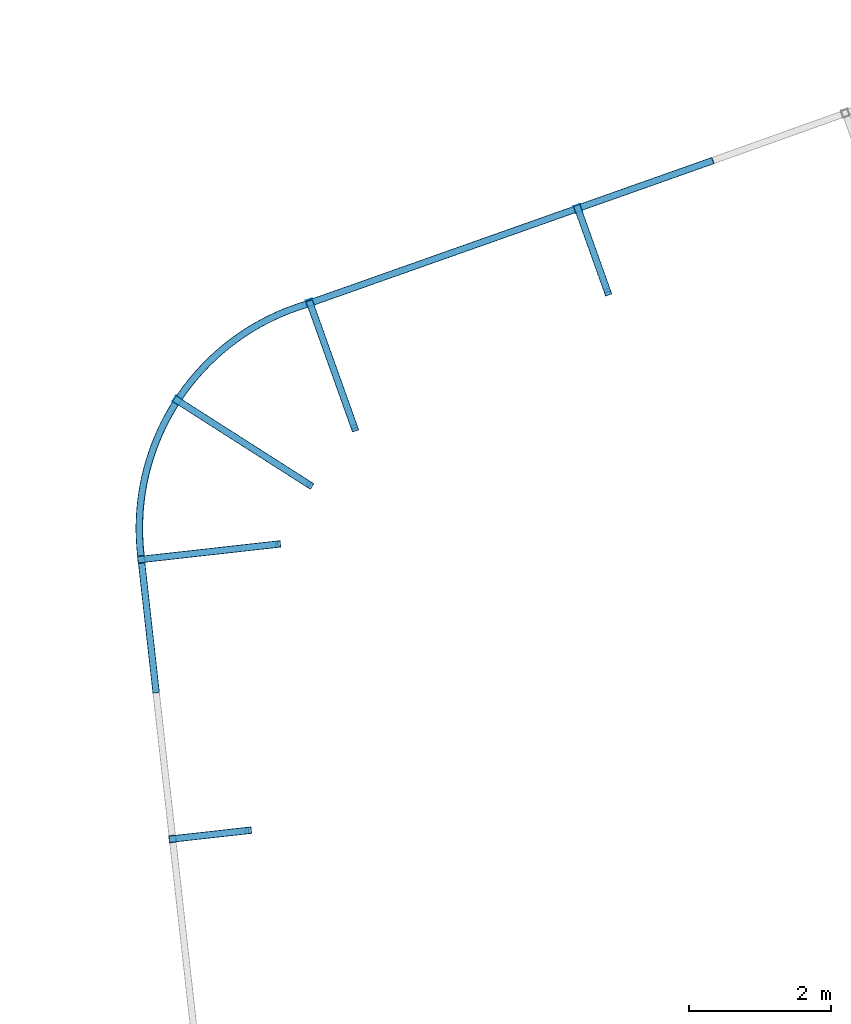
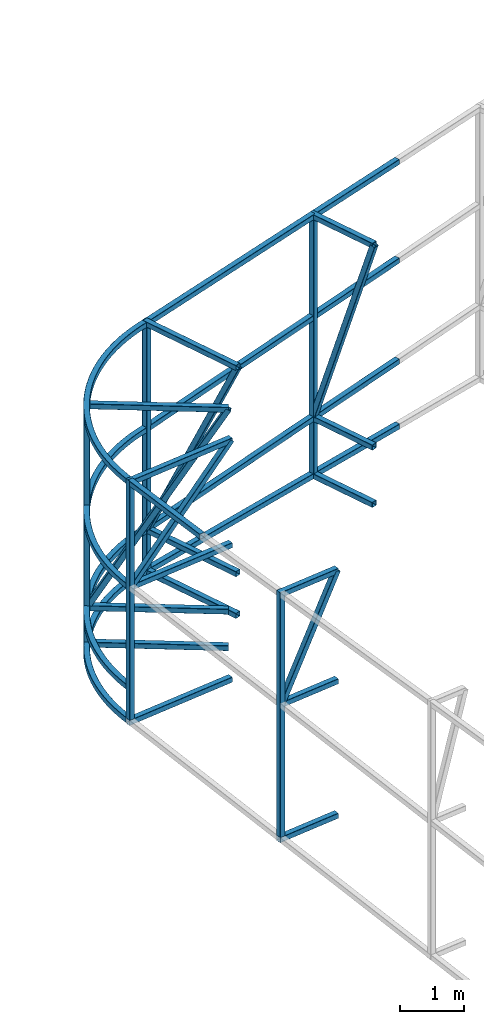
# One storey, part 126 of 215: 29 beams, 5 members, 34 elements without a shape of their own.
"""IFC2X3 building model written with IfcOpenShell, lengths in millimetres."""

from ifc_helpers import new_model, entity, si_unit, frame, origin_with_axes, origin_2d_with_axis, place, context, subcontext, project, spatial, hollow_rectangle, extrude, material, type_object, element, aggregate, save


model = new_model("IFC2X3")

# Units and contexts
model_context = context("Model", 3, precision=1e-05, world=origin_with_axes())
body_context = subcontext(model_context, "Body", "Model", "MODEL_VIEW")
ifc_project = project(units=[si_unit("LENGTHUNIT", "METRE", prefix="MILLI"), si_unit("AREAUNIT", "SQUARE_METRE"), si_unit("VOLUMEUNIT", "CUBIC_METRE"), si_unit("MASSUNIT", "GRAM", prefix="KILO"), si_unit("TIMEUNIT", "SECOND"), si_unit("PLANEANGLEUNIT", "RADIAN"), si_unit("SOLIDANGLEUNIT", "STERADIAN"), si_unit("THERMODYNAMICTEMPERATUREUNIT", "DEGREE_CELSIUS"), si_unit("LUMINOUSINTENSITYUNIT", "LUMEN")], contexts=[model_context])

# Site, building, storey
site_placement = place(None, origin_with_axes())
site = spatial("IfcSite", under=ifc_project, at=site_placement, CompositionType="ELEMENT")
building_placement = place(site_placement, origin_with_axes())
building = spatial("IfcBuilding", under=site, at=building_placement, Name="Undefined", CompositionType="ELEMENT")
storey_placement = place(building_placement, origin_with_axes())
storey = spatial("IfcBuildingStorey", under=building, at=storey_placement, Name="Undefined", CompositionType="ELEMENT", Elevation=0.0)

# Assembly, beam
assembly_1_placement = place(storey_placement, origin_with_axes())
assembly_1 = element("IfcElementAssembly", 1, at=assembly_1_placement, inside=storey, Name="Steel Assembly", AssemblyPlace="NOTDEFINED", PredefinedType="RIGID_FRAME")
ifc_material = material(Name="STEEL/S275JR")
beam_type = type_object("IfcBeamType", PredefinedType="NOTDEFINED")
beam_1_placement = place(assembly_1_placement, frame((91607.248032697, 68580.9446673128, 2617.76875948124), z_axis=(0.834469392374245, -0.550396256246836, -0.0269220040120741), x_axis=(0.549440398154308, 0.834768266234439, -0.0357378030100368)))
beam_1 = element("IfcBeam", 2, at=beam_1_placement, type_object=beam_type, material=ifc_material, Name="LISSE", context=body_context, shape_type="SweptSolid", body=[
    entity("IfcRevolvedAreaSolid", entity("IfcRectangleHollowProfileDef", "AREA", None, entity("IfcAxis2Placement2D", entity("IfcCartesianPoint", [0.0, 0.0]), entity("IfcDirection", [1.0, 0.0])), 100.0, 100.0, 4.0, 4.0, 8.0), entity("IfcAxis2Placement3D", entity("IfcCartesianPoint", [4253.07055519195, -2.95116053483087e-14, -7.49913912963001e-12]), entity("IfcDirection", [-0.764684688863916, 7.54179360387119e-18, -0.644404629574537]), entity("IfcDirection", [-6.93889390390723e-18, -1.0, -3.46944695195361e-18])), entity("IfcAxis1Placement", entity("IfcCartesianPoint", [0.0, 3300.0, 0.0]), entity("IfcDirection", [-1.0, 0.0, 0.0])), 1.40048888931298),
])
aggregate(assembly_1, [beam_1])

assembly_2_placement = place(storey_placement, origin_with_axes())
assembly_2 = element("IfcElementAssembly", 3, at=assembly_2_placement, inside=storey, Name="Steel Assembly", AssemblyPlace="NOTDEFINED", PredefinedType="RIGID_FRAME")
beam_2_placement = place(assembly_2_placement, frame((93991.6038532737, 72148.0113620738, 2462.13444631614), z_axis=(-0.0695733440169439, -0.0246100800059907, -0.997273229242818), x_axis=(0.940198367836506, 0.332537099942175, -0.0737977389871672)))
beam_2 = element("IfcBeam", 4, at=beam_2_placement, type_object=beam_type, material=ifc_material, Name="LISSE", context=body_context, shape_type="SweptSolid", body=[
    extrude(hollow_rectangle(XDim=100.0, YDim=100.0, WallThickness=4.0, InnerFilletRadius=4.0, OuterFilletRadius=8.0, at=origin_2d_with_axis()), frame((6049.10274749353, -7.56716882113975e-12, 8.39481643573826e-14), z_axis=(-1.0, 0.0, 0.0), x_axis=(-6.93889390390723e-18, -1.0, -3.46944695195361e-18)), (0.0, 0.0, 1.0), 6049.1),
])
aggregate(assembly_2, [beam_2])

assembly_3_placement = place(storey_placement, origin_with_axes())
assembly_3 = element("IfcElementAssembly", 5, at=assembly_3_placement, inside=storey, Name="Steel Assembly", AssemblyPlace="NOTDEFINED", PredefinedType="RIGID_FRAME")
beam_3_placement = place(assembly_3_placement, frame((91605.3363023384, 68580.2609110782, 7185.12016069465), z_axis=(0.835271355040967, -0.549834651026962, 0.00190262400009359), x_axis=(0.549829823840989, 0.835272824758436, 0.00254421599926422)))
beam_3 = element("IfcBeam", 6, at=beam_3_placement, type_object=beam_type, material=ifc_material, Name="LISSE", context=body_context, shape_type="SweptSolid", body=[
    entity("IfcRevolvedAreaSolid", entity("IfcRectangleHollowProfileDef", "AREA", None, entity("IfcAxis2Placement2D", entity("IfcCartesianPoint", [0.0, 0.0]), entity("IfcDirection", [1.0, 0.0])), 100.0, 100.0, 4.0, 4.0, 8.0), entity("IfcAxis2Placement3D", entity("IfcCartesianPoint", [4250.63753103631, 9.07651281594689e-13, 1.46771453858659e-11]), entity("IfcDirection", [-0.764995192248369, 3.31763779750659e-19, -0.644035989550958]), entity("IfcDirection", [-6.93889390390723e-18, -1.0, -3.46944695195361e-18])), entity("IfcAxis1Placement", entity("IfcCartesianPoint", [0.0, 3300.0, 0.0]), entity("IfcDirection", [-1.0, 0.0, 0.0])), 1.39952492287531),
])
aggregate(assembly_3, [beam_3])

assembly_4_placement = place(storey_placement, origin_with_axes())
assembly_4 = element("IfcElementAssembly", 7, at=assembly_4_placement, inside=storey, Name="Steel Assembly", AssemblyPlace="NOTDEFINED", PredefinedType="RIGID_FRAME")
beam_4_placement = place(assembly_4_placement, frame((93992.0527159489, 72148.1696476827, 7194.91794063586), z_axis=(-0.0194644239945866, -0.00689095799808525, -0.999786802721674), x_axis=(0.942568087150264, 0.333375242053147, -0.0206482220032917)))
beam_4 = element("IfcBeam", 8, at=beam_4_placement, type_object=beam_type, material=ifc_material, Name="LISSE", context=body_context, shape_type="SweptSolid", body=[
    extrude(hollow_rectangle(XDim=100.0, YDim=100.0, WallThickness=4.0, InnerFilletRadius=4.0, OuterFilletRadius=8.0, at=origin_2d_with_axis()), frame((6028.69527728381, -7.7446509143902e-14, 1.79807316509183e-12), z_axis=(-1.0, 0.0, 0.0), x_axis=(-6.93889390390723e-18, -1.0, -3.46944695195361e-18)), (0.0, 0.0, 1.0), 6028.7),
])
aggregate(assembly_4, [beam_4])

assembly_5_placement = place(storey_placement, origin_with_axes())
assembly_5 = element("IfcElementAssembly", 9, at=assembly_5_placement, inside=storey, Name="Steel Assembly", AssemblyPlace="NOTDEFINED", PredefinedType="RIGID_FRAME")
beam_5_placement = place(assembly_5_placement, frame((93124.0754360827, 64705.462066783, 2619.99965660268), z_axis=(-0.111241487973639, 0.993793404764497, 0.0), x_axis=(-0.993793404764496, -0.111241487973643, 0.0)))
beam_5 = element("IfcBeam", 10, at=beam_5_placement, type_object=beam_type, material=ifc_material, Name="LISSE", context=body_context, shape_type="SweptSolid", body=[
    extrude(hollow_rectangle(XDim=100.0, YDim=100.0, WallThickness=4.0, InnerFilletRadius=4.0, OuterFilletRadius=8.0, at=origin_2d_with_axis()), frame((1128.31775918118, 0.0, 0.0), z_axis=(-1.0, 0.0, 0.0), x_axis=(-6.93889390390723e-18, -1.0, -3.46944695195361e-18)), (0.0, 0.0, 1.0), 1128.3),
])
aggregate(assembly_5, [beam_5])

assembly_6_placement = place(storey_placement, origin_with_axes())
assembly_6 = element("IfcElementAssembly", 11, at=assembly_6_placement, inside=storey, Name="Steel Assembly", AssemblyPlace="NOTDEFINED", PredefinedType="RIGID_FRAME")
beam_6_placement = place(assembly_6_placement, frame((93124.0754354593, 64705.4620598467, 5185.9679099935), z_axis=(-0.111241487973639, 0.993793404764497, 0.0), x_axis=(-0.993793404764496, -0.111241487973643, 0.0)))
beam_6 = element("IfcBeam", 12, at=beam_6_placement, type_object=beam_type, material=ifc_material, Name="LISSE", context=body_context, shape_type="SweptSolid", body=[
    extrude(hollow_rectangle(XDim=100.0, YDim=100.0, WallThickness=4.0, InnerFilletRadius=4.0, OuterFilletRadius=8.0, at=origin_2d_with_axis()), frame((1128.31775918118, 0.0, 0.0), z_axis=(-1.0, 0.0, 0.0), x_axis=(-6.93889390390723e-18, -1.0, -3.46944695195361e-18)), (0.0, 0.0, 1.0), 1128.3),
])
aggregate(assembly_6, [beam_6])

assembly_7_placement = place(storey_placement, origin_with_axes())
assembly_7 = element("IfcElementAssembly", 13, at=assembly_7_placement, inside=storey, Name="Steel Assembly", AssemblyPlace="NOTDEFINED", PredefinedType="RIGID_FRAME")
beam_7_placement = place(assembly_7_placement, frame((93124.0754363296, 64705.4620685317, 7292.68372931973), z_axis=(-0.111241487973639, 0.993793404764497, 0.0), x_axis=(-0.993793404764496, -0.111241487973643, 0.0)))
beam_7 = element("IfcBeam", 14, at=beam_7_placement, type_object=beam_type, material=ifc_material, Name="LISSE", context=body_context, shape_type="SweptSolid", body=[
    extrude(hollow_rectangle(XDim=100.0, YDim=100.0, WallThickness=4.0, InnerFilletRadius=4.0, OuterFilletRadius=8.0, at=origin_2d_with_axis()), frame((1128.31775918118, 0.0, 0.0), z_axis=(-1.0, 0.0, 0.0), x_axis=(-6.93889390390723e-18, -1.0, -3.46944695195361e-18)), (0.0, 0.0, 1.0), 1128.3),
])
aggregate(assembly_7, [beam_7])

assembly_8_placement = place(storey_placement, origin_with_axes())
assembly_8 = element("IfcElementAssembly", 15, at=assembly_8_placement, inside=storey, Name="Steel Assembly", AssemblyPlace="NOTDEFINED", PredefinedType="RIGID_FRAME")
beam_8_placement = place(assembly_8_placement, frame((92052.3278067538, 64585.4969557288, 7341.91481389549), z_axis=(-0.111238280970791, 0.993793763739068, 0.0), x_axis=(0.0, 0.0, -1.0)))
beam_8 = element("IfcBeam", 16, at=beam_8_placement, type_object=beam_type, material=ifc_material, Name="LISSE", context=body_context, shape_type="SweptSolid", body=[
    extrude(hollow_rectangle(XDim=100.0, YDim=100.0, WallThickness=4.0, InnerFilletRadius=4.0, OuterFilletRadius=8.0, at=origin_2d_with_axis()), frame((4671.91515736343, 0.0, 0.0), z_axis=(-1.0, 0.0, 0.0), x_axis=(-6.93889390390723e-18, -1.0, -3.46944695195361e-18)), (0.0, 0.0, 1.0), 4671.9),
])
aggregate(assembly_8, [beam_8])

assembly_9_placement = place(storey_placement, origin_with_axes())
assembly_9 = element("IfcElementAssembly", 17, at=assembly_9_placement, inside=storey, Name="Steel Assembly", AssemblyPlace="NOTDEFINED", PredefinedType="RIGID_FRAME")
beam_9_placement = place(assembly_9_placement, frame((91605.1866103333, 68580.2059175499, 3259.91320502484), z_axis=(0.835301858925206, -0.549791600950776, 2.8100000006119e-07), x_axis=(0.54979160084285, 0.83530185876124, 1.98159999943166e-05)))
beam_9 = element("IfcBeam", 18, at=beam_9_placement, type_object=beam_type, material=ifc_material, Name="LISSE", context=body_context, shape_type="SweptSolid", body=[
    entity("IfcRevolvedAreaSolid", entity("IfcRectangleHollowProfileDef", "AREA", None, entity("IfcAxis2Placement2D", entity("IfcCartesianPoint", [0.0, 0.0]), entity("IfcDirection", [1.0, 0.0])), 100.0, 100.0, 4.0, 4.0, 8.0), entity("IfcAxis2Placement3D", entity("IfcCartesianPoint", [4250.35466927494, -4.54747350886464e-13, -1.17235734839679e-13]), entity("IfcDirection", [-0.765031271460523, 6.81854250453037e-23, -0.643993131708325]), entity("IfcDirection", [-6.93889390390723e-18, -1.0, -3.46944695195361e-18])), entity("IfcAxis1Placement", entity("IfcCartesianPoint", [0.0, 3300.0, 0.0]), entity("IfcDirection", [-1.0, 0.0, 0.0])), 1.39941287816592),
])
aggregate(assembly_9, [beam_9])

assembly_10_placement = place(storey_placement, origin_with_axes())
assembly_10 = element("IfcElementAssembly", 19, at=assembly_10_placement, inside=storey, Name="Steel Assembly", AssemblyPlace="NOTDEFINED", PredefinedType="RIGID_FRAME")
beam_10_placement = place(assembly_10_placement, frame((93988.3220008823, 69580.9742810652, 2563.10415518679), z_axis=(0.538048002179701, 0.842914199281536, 0.0), x_axis=(-0.84291419928153, 0.53804800217971, 0.0)))
beam_10 = element("IfcBeam", 20, at=beam_10_placement, type_object=beam_type, material=ifc_material, Name="LISSE", context=body_context, shape_type="SweptSolid", body=[
    extrude(hollow_rectangle(XDim=100.0, YDim=100.0, WallThickness=4.0, InnerFilletRadius=4.0, OuterFilletRadius=8.0, at=origin_2d_with_axis()), frame((2265.76907289685, 9.09494701772928e-13, 0.0), z_axis=(-1.0, 0.0, 0.0), x_axis=(-6.93889390390723e-18, -1.0, -3.46944695195361e-18)), (0.0, 0.0, 1.0), 2265.8),
])
aggregate(assembly_10, [beam_10])

assembly_11_placement = place(storey_placement, origin_with_axes())
assembly_11 = element("IfcElementAssembly", 21, at=assembly_11_placement, inside=storey, Name="Steel Assembly", AssemblyPlace="NOTDEFINED", PredefinedType="RIGID_FRAME")
beam_11_placement = place(assembly_11_placement, frame((93988.3219862734, 69580.9742607671, 3259.9979099935), z_axis=(0.538048002179701, 0.842914199281536, 0.0), x_axis=(-0.84291419928153, 0.53804800217971, 0.0)))
beam_11 = element("IfcBeam", 22, at=beam_11_placement, type_object=beam_type, material=ifc_material, Name="LISSE", context=body_context, shape_type="SweptSolid", body=[
    extrude(hollow_rectangle(XDim=100.0, YDim=100.0, WallThickness=4.0, InnerFilletRadius=4.0, OuterFilletRadius=8.0, at=origin_2d_with_axis()), frame((2265.76907289685, 9.09494701772928e-13, 0.0), z_axis=(-1.0, 0.0, 0.0), x_axis=(-6.93889390390723e-18, -1.0, -3.46944695195361e-18)), (0.0, 0.0, 1.0), 2265.8),
])
aggregate(assembly_11, [beam_11])

assembly_12_placement = place(storey_placement, origin_with_axes())
assembly_12 = element("IfcElementAssembly", 23, at=assembly_12_placement, inside=storey, Name="Steel Assembly", AssemblyPlace="NOTDEFINED", PredefinedType="RIGID_FRAME")
beam_12_placement = place(assembly_12_placement, frame((93988.3219924647, 69580.9742671399, 7112.12473911374), z_axis=(0.538048002179701, 0.842914199281536, 0.0), x_axis=(-0.84291419928153, 0.53804800217971, 0.0)))
beam_12 = element("IfcBeam", 24, at=beam_12_placement, type_object=beam_type, material=ifc_material, Name="LISSE", context=body_context, shape_type="SweptSolid", body=[
    extrude(hollow_rectangle(XDim=100.0, YDim=100.0, WallThickness=4.0, InnerFilletRadius=4.0, OuterFilletRadius=8.0, at=origin_2d_with_axis()), frame((2265.76907289685, 9.09494701772928e-13, 0.0), z_axis=(-1.0, 0.0, 0.0), x_axis=(-6.93889390390723e-18, -1.0, -3.46944695195361e-18)), (0.0, 0.0, 1.0), 2265.8),
])
aggregate(assembly_12, [beam_12])

assembly_13_placement = place(storey_placement, origin_with_axes())
assembly_13 = element("IfcElementAssembly", 25, at=assembly_13_placement, inside=storey, Name="Steel Assembly", AssemblyPlace="NOTDEFINED", PredefinedType="RIGID_FRAME")
beam_13_placement = place(assembly_13_placement, frame((92120.6199483279, 70773.166223234, 7128.20752686907), z_axis=(0.53801131887407, 0.842937613802696, 4.00000044371208e-09), x_axis=(0.0, 0.0, -1.0)))
beam_13 = element("IfcBeam", 26, at=beam_13_placement, type_object=beam_type, material=ifc_material, Name="LISSE", context=body_context, shape_type="SweptSolid", body=[
    extrude(hollow_rectangle(XDim=100.0, YDim=100.0, WallThickness=4.0, InnerFilletRadius=4.0, OuterFilletRadius=8.0, at=origin_2d_with_axis()), frame((4514.77028501296, 4.66816306236654e-22, 0.0), z_axis=(-1.0, 0.0, 0.0), x_axis=(-6.93889390390723e-18, -1.0, -3.46944695195361e-18)), (0.0, 0.0, 1.0), 4514.8),
])
aggregate(assembly_13, [beam_13])

assembly_14_placement = place(storey_placement, origin_with_axes())
assembly_14 = element("IfcElementAssembly", 27, at=assembly_14_placement, inside=storey, Name="Steel Assembly", AssemblyPlace="NOTDEFINED", PredefinedType="RIGID_FRAME")
beam_14_placement = place(assembly_14_placement, frame((93944.4191635275, 72131.3225535443, 5186.05790994558), z_axis=(0.0, 0.0, -1.0), x_axis=(0.942769082912834, 0.333446331969171, 0.0)))
beam_14 = element("IfcBeam", 28, at=beam_14_placement, type_object=beam_type, material=ifc_material, Name="LISSE", context=body_context, shape_type="SweptSolid", body=[
    extrude(hollow_rectangle(XDim=100.0, YDim=100.0, WallThickness=4.0, InnerFilletRadius=4.0, OuterFilletRadius=8.0, at=origin_2d_with_axis()), frame((6078.96742064633, 0.0, 0.0), z_axis=(-1.0, 0.0, 0.0), x_axis=(-6.93889390390723e-18, -1.0, -3.46944695195361e-18)), (0.0, 0.0, 1.0), 6079.0),
])
aggregate(assembly_14, [beam_14])

assembly_15_placement = place(storey_placement, origin_with_axes())
assembly_15 = element("IfcElementAssembly", 29, at=assembly_15_placement, inside=storey, Name="Steel Assembly", AssemblyPlace="NOTDEFINED", PredefinedType="RIGID_FRAME")
beam_15_placement = place(assembly_15_placement, frame((93542.942494113, 68746.4892120415, 2619.99965660268), z_axis=(-0.111241487973639, 0.993793404764497, 0.0), x_axis=(-0.993793404764496, -0.111241487973643, 0.0)))
beam_15 = element("IfcBeam", 30, at=beam_15_placement, type_object=beam_type, material=ifc_material, Name="LISSE", context=body_context, shape_type="SweptSolid", body=[
    extrude(hollow_rectangle(XDim=100.0, YDim=100.0, WallThickness=4.0, InnerFilletRadius=4.0, OuterFilletRadius=8.0, at=origin_2d_with_axis()), frame((1994.10214224398, -4.54747350886464e-13, 0.0), z_axis=(-1.0, 0.0, 0.0), x_axis=(-6.93889390390723e-18, -1.0, -3.46944695195361e-18)), (0.0, 0.0, 1.0), 1994.1),
])
aggregate(assembly_15, [beam_15])

assembly_16_placement = place(storey_placement, origin_with_axes())
assembly_16 = element("IfcElementAssembly", 31, at=assembly_16_placement, inside=storey, Name="Steel Assembly", AssemblyPlace="NOTDEFINED", PredefinedType="RIGID_FRAME")
beam_16_placement = place(assembly_16_placement, frame((93542.9424934897, 68746.4892051052, 5185.9679099935), z_axis=(-0.111241487973639, 0.993793404764497, 0.0), x_axis=(-0.993793404764496, -0.111241487973643, 0.0)))
beam_16 = element("IfcBeam", 32, at=beam_16_placement, type_object=beam_type, material=ifc_material, Name="LISSE", context=body_context, shape_type="SweptSolid", body=[
    extrude(hollow_rectangle(XDim=100.0, YDim=100.0, WallThickness=4.0, InnerFilletRadius=4.0, OuterFilletRadius=8.0, at=origin_2d_with_axis()), frame((1994.10214224398, -4.54747350886464e-13, 0.0), z_axis=(-1.0, 0.0, 0.0), x_axis=(-6.93889390390723e-18, -1.0, -3.46944695195361e-18)), (0.0, 0.0, 1.0), 1994.1),
])
aggregate(assembly_16, [beam_16])

assembly_17_placement = place(storey_placement, origin_with_axes())
assembly_17 = element("IfcElementAssembly", 33, at=assembly_17_placement, inside=storey, Name="Steel Assembly", AssemblyPlace="NOTDEFINED", PredefinedType="RIGID_FRAME")
beam_17_placement = place(assembly_17_placement, frame((93542.9424943203, 68746.4892139614, 7185.73412055693), z_axis=(-0.111241487973639, 0.993793404764497, 0.0), x_axis=(-0.993793404764496, -0.111241487973643, 0.0)))
beam_17 = element("IfcBeam", 34, at=beam_17_placement, type_object=beam_type, material=ifc_material, Name="LISSE", context=body_context, shape_type="SweptSolid", body=[
    extrude(hollow_rectangle(XDim=100.0, YDim=100.0, WallThickness=4.0, InnerFilletRadius=4.0, OuterFilletRadius=8.0, at=origin_2d_with_axis()), frame((1994.10214224398, -4.54747350886464e-13, 0.0), z_axis=(-1.0, 0.0, 0.0), x_axis=(-6.93889390390723e-18, -1.0, -3.46944695195361e-18)), (0.0, 0.0, 1.0), 1994.1),
])
aggregate(assembly_17, [beam_17])

assembly_18_placement = place(storey_placement, origin_with_axes())
assembly_18 = element("IfcElementAssembly", 35, at=assembly_18_placement, inside=storey, Name="Steel Assembly", AssemblyPlace="NOTDEFINED", PredefinedType="RIGID_FRAME")
beam_18_placement = place(assembly_18_placement, frame((91610.7840567049, 68530.212942063, 7234.96520513335), z_axis=(-0.111238280970791, 0.993793763739068, 0.0), x_axis=(0.0, 0.0, -1.0)))
beam_18 = element("IfcBeam", 36, at=beam_18_placement, type_object=beam_type, material=ifc_material, Name="LISSE", context=body_context, shape_type="SweptSolid", body=[
    extrude(hollow_rectangle(XDim=100.0, YDim=100.0, WallThickness=4.0, InnerFilletRadius=4.0, OuterFilletRadius=8.0, at=origin_2d_with_axis()), frame((4564.96554860063, 0.0, 0.0), z_axis=(-1.0, 0.0, 0.0), x_axis=(-6.93889390390723e-18, -1.0, -3.46944695195361e-18)), (0.0, 0.0, 1.0), 4565.0),
])
aggregate(assembly_18, [beam_18])

assembly_19_placement = place(storey_placement, origin_with_axes())
assembly_19 = element("IfcElementAssembly", 37, at=assembly_19_placement, inside=storey, Name="Steel Assembly", AssemblyPlace="NOTDEFINED", PredefinedType="RIGID_FRAME")
beam_19_placement = place(assembly_19_placement, frame((91605.3109735335, 68579.1329490812, 7184.97387043325), z_axis=(0.993793762306238, 0.111238281034276, 5.32330000160401e-05), x_axis=(0.111224923052655, -0.993674430470426, 0.0154965390073363)))
beam_19 = element("IfcBeam", 38, at=beam_19_placement, type_object=beam_type, material=ifc_material, Name="LISSE", context=body_context, shape_type="SweptSolid", body=[
    extrude(hollow_rectangle(XDim=100.0, YDim=100.0, WallThickness=4.0, InnerFilletRadius=4.0, OuterFilletRadius=8.0, at=origin_2d_with_axis()), frame((1944.61632049286, -9.12868073355855e-13, -1.45545181436227e-11), z_axis=(-1.0, 0.0, 0.0), x_axis=(-6.93889390390723e-18, -1.0, -3.46944695195361e-18)), (0.0, 0.0, 1.0), 1944.6),
])
aggregate(assembly_19, [beam_19])

assembly_20_placement = place(storey_placement, origin_with_axes())
assembly_20 = element("IfcElementAssembly", 39, at=assembly_20_placement, inside=storey, Name="Steel Assembly", AssemblyPlace="NOTDEFINED", PredefinedType="RIGID_FRAME")
beam_20_placement = place(assembly_20_placement, frame((94621.8677313314, 70382.7951345601, 7194.93442467208), z_axis=(0.941761903686529, 0.336280413888061, 0.0), x_axis=(-0.33628041388807, 0.941761903686526, 0.0)))
beam_20 = element("IfcBeam", 40, at=beam_20_placement, type_object=beam_type, material=ifc_material, Name="LISSE", context=body_context, shape_type="SweptSolid", body=[
    extrude(hollow_rectangle(XDim=100.0, YDim=100.0, WallThickness=4.0, InnerFilletRadius=4.0, OuterFilletRadius=8.0, at=origin_2d_with_axis()), frame((1907.12525980321, 0.0, -1.46577819470807e-11), z_axis=(-1.0, 0.0, 0.0), x_axis=(-6.93889390390723e-18, -1.0, -3.46944695195361e-18)), (0.0, 0.0, 1.0), 1907.1),
])
aggregate(assembly_20, [beam_20])

assembly_21_placement = place(storey_placement, origin_with_axes())
assembly_21 = element("IfcElementAssembly", 41, at=assembly_21_placement, inside=storey, Name="Steel Assembly", AssemblyPlace="NOTDEFINED", PredefinedType="RIGID_FRAME")
beam_21_placement = place(assembly_21_placement, frame((94622.0051090536, 70382.8441690665, 2462.13794535515), z_axis=(0.941761903686529, 0.336280413888061, 0.0), x_axis=(-0.33628041388807, 0.941761903686526, 0.0)))
beam_21 = element("IfcBeam", 42, at=beam_21_placement, type_object=beam_type, material=ifc_material, Name="LISSE", context=body_context, shape_type="SweptSolid", body=[
    extrude(hollow_rectangle(XDim=100.0, YDim=100.0, WallThickness=4.0, InnerFilletRadius=4.0, OuterFilletRadius=8.0, at=origin_2d_with_axis()), frame((1907.12525980321, 0.0, -1.46577819470807e-11), z_axis=(-1.0, 0.0, 0.0), x_axis=(-6.93889390390723e-18, -1.0, -3.46944695195361e-18)), (0.0, 0.0, 1.0), 1907.1),
])
aggregate(assembly_21, [beam_21])

assembly_22_placement = place(storey_placement, origin_with_axes())
assembly_22 = element("IfcElementAssembly", 43, at=assembly_22_placement, inside=storey, Name="Steel Assembly", AssemblyPlace="NOTDEFINED", PredefinedType="RIGID_FRAME")
beam_22_placement = place(assembly_22_placement, frame((94622.0066629539, 70382.8447246901, 3259.9979099935), z_axis=(0.941761903686529, 0.336280413888061, 0.0), x_axis=(-0.33628041388807, 0.941761903686526, 0.0)))
beam_22 = element("IfcBeam", 44, at=beam_22_placement, type_object=beam_type, material=ifc_material, Name="LISSE", context=body_context, shape_type="SweptSolid", body=[
    extrude(hollow_rectangle(XDim=100.0, YDim=100.0, WallThickness=4.0, InnerFilletRadius=4.0, OuterFilletRadius=8.0, at=origin_2d_with_axis()), frame((1907.12525980321, 0.0, -1.46577819470807e-11), z_axis=(-1.0, 0.0, 0.0), x_axis=(-6.93889390390723e-18, -1.0, -3.46944695195361e-18)), (0.0, 0.0, 1.0), 1907.1),
])
aggregate(assembly_22, [beam_22])

assembly_23_placement = place(storey_placement, origin_with_axes())
assembly_23 = element("IfcElementAssembly", 45, at=assembly_23_placement, inside=storey, Name="Steel Assembly", AssemblyPlace="NOTDEFINED", PredefinedType="RIGID_FRAME")
beam_23_placement = place(assembly_23_placement, frame((98193.2165753168, 72303.7208093414, 2165.44750818393), z_axis=(0.941802170974673, 0.33616762299096, 0.0), x_axis=(-0.336167626855526, 0.941802169595252, 0.0)))
beam_23 = element("IfcBeam", 46, at=beam_23_placement, type_object=beam_type, material=ifc_material, Name="LISSE", context=body_context, shape_type="SweptSolid", body=[
    extrude(hollow_rectangle(XDim=100.0, YDim=100.0, WallThickness=4.0, InnerFilletRadius=4.0, OuterFilletRadius=8.0, at=origin_2d_with_axis()), frame((1298.54286512527, -4.54747350886464e-13, -7.208360936624e-14), z_axis=(-1.0, 0.0, 0.0), x_axis=(-6.93889390390723e-18, -1.0, -3.46944695195361e-18)), (0.0, 0.0, 1.0), 1298.5),
])
aggregate(assembly_23, [beam_23])

assembly_24_placement = place(storey_placement, origin_with_axes())
assembly_24 = element("IfcElementAssembly", 47, at=assembly_24_placement, inside=storey, Name="Steel Assembly", AssemblyPlace="NOTDEFINED", PredefinedType="RIGID_FRAME")
beam_24_placement = place(assembly_24_placement, frame((98193.2165684213, 72303.7208083644, 3259.9979099935), z_axis=(0.941802170974673, 0.33616762299096, 0.0), x_axis=(-0.336167626855526, 0.941802169595252, 0.0)))
beam_24 = element("IfcBeam", 48, at=beam_24_placement, type_object=beam_type, material=ifc_material, Name="LISSE", context=body_context, shape_type="SweptSolid", body=[
    extrude(hollow_rectangle(XDim=100.0, YDim=100.0, WallThickness=4.0, InnerFilletRadius=4.0, OuterFilletRadius=8.0, at=origin_2d_with_axis()), frame((1298.54286512527, -4.54747350886464e-13, -7.208360936624e-14), z_axis=(-1.0, 0.0, 0.0), x_axis=(-6.93889390390723e-18, -1.0, -3.46944695195361e-18)), (0.0, 0.0, 1.0), 1298.5),
])
aggregate(assembly_24, [beam_24])

assembly_25_placement = place(storey_placement, origin_with_axes())
assembly_25 = element("IfcElementAssembly", 49, at=assembly_25_placement, inside=storey, Name="Steel Assembly", AssemblyPlace="NOTDEFINED", PredefinedType="RIGID_FRAME")
beam_25_placement = place(assembly_25_placement, frame((98193.2165772194, 72303.720809604, 7112.12473911374), z_axis=(0.941802170974673, 0.33616762299096, 0.0), x_axis=(-0.336167626855526, 0.941802169595252, 0.0)))
beam_25 = element("IfcBeam", 50, at=beam_25_placement, type_object=beam_type, material=ifc_material, Name="LISSE", context=body_context, shape_type="SweptSolid", body=[
    extrude(hollow_rectangle(XDim=100.0, YDim=100.0, WallThickness=4.0, InnerFilletRadius=4.0, OuterFilletRadius=8.0, at=origin_2d_with_axis()), frame((1298.54286512527, -4.54747350886464e-13, -7.208360936624e-14), z_axis=(-1.0, 0.0, 0.0), x_axis=(-6.93889390390723e-18, -1.0, -3.46944695195361e-18)), (0.0, 0.0, 1.0), 1298.5),
])
aggregate(assembly_25, [beam_25])

assembly_26_placement = place(storey_placement, origin_with_axes())
assembly_26 = element("IfcElementAssembly", 51, at=assembly_26_placement, inside=storey, Name="Steel Assembly", AssemblyPlace="NOTDEFINED", PredefinedType="RIGID_FRAME")
beam_26_placement = place(assembly_26_placement, frame((97773.4968839704, 73479.6011886863, 7128.20752687202), z_axis=(0.941802170974673, 0.33616762299096, 0.0), x_axis=(0.0, 0.0, -1.0)))
beam_26 = element("IfcBeam", 52, at=beam_26_placement, type_object=beam_type, material=ifc_material, Name="LISSE", context=body_context, shape_type="SweptSolid", body=[
    extrude(hollow_rectangle(XDim=100.0, YDim=100.0, WallThickness=4.0, InnerFilletRadius=4.0, OuterFilletRadius=8.0, at=origin_2d_with_axis()), frame((4912.42693201552, 0.0, 0.0), z_axis=(-1.0, 0.0, 0.0), x_axis=(-6.93889390390723e-18, -1.0, -3.46944695195361e-18)), (0.0, 0.0, 1.0), 4912.4),
])
aggregate(assembly_26, [beam_26])

assembly_27_placement = place(storey_placement, origin_with_axes())
assembly_27 = element("IfcElementAssembly", 53, at=assembly_27_placement, inside=storey, Name="Steel Assembly", AssemblyPlace="NOTDEFINED", PredefinedType="RIGID_FRAME")
beam_27_placement = place(assembly_27_placement, frame((93991.6451843343, 72148.1789278337, 7243.91245560067), z_axis=(0.941804037353502, 0.336162394126178, 0.0), x_axis=(0.0, 0.0, -1.0)))
beam_27 = element("IfcBeam", 54, at=beam_27_placement, type_object=beam_type, material=ifc_material, Name="LISSE", context=body_context, shape_type="SweptSolid", body=[
    extrude(hollow_rectangle(XDim=100.0, YDim=100.0, WallThickness=4.0, InnerFilletRadius=4.0, OuterFilletRadius=8.0, at=origin_2d_with_axis()), frame((4828.21124526049, -7.27595761418343e-12, 1.45519152283669e-11), z_axis=(-1.0, 0.0, 0.0), x_axis=(-6.93889390390723e-18, -1.0, -3.46944695195361e-18)), (0.0, 0.0, 1.0), 4828.2),
])
aggregate(assembly_27, [beam_27])

assembly_28_placement = place(storey_placement, origin_with_axes())
assembly_28 = element("IfcElementAssembly", 55, at=assembly_28_placement, inside=storey, Name="Steel Assembly", AssemblyPlace="NOTDEFINED", PredefinedType="RIGID_FRAME")
beam_28_placement = place(assembly_28_placement, frame((93944.4191635059, 72131.3225535103, 3259.99790994558), z_axis=(0.0, 0.0, -1.0), x_axis=(0.942769082912834, 0.333446331969171, 0.0)))
beam_28 = element("IfcBeam", 56, at=beam_28_placement, type_object=beam_type, material=ifc_material, Name="LISSE", context=body_context, shape_type="SweptSolid", body=[
    extrude(hollow_rectangle(XDim=100.0, YDim=100.0, WallThickness=4.0, InnerFilletRadius=4.0, OuterFilletRadius=8.0, at=origin_2d_with_axis()), frame((6078.96742064633, 0.0, 0.0), z_axis=(-1.0, 0.0, 0.0), x_axis=(-6.93889390390723e-18, -1.0, -3.46944695195361e-18)), (0.0, 0.0, 1.0), 6079.0),
])
aggregate(assembly_28, [beam_28])

assembly_29_placement = place(storey_placement, origin_with_axes())
assembly_29 = element("IfcElementAssembly", 57, at=assembly_29_placement, inside=storey, Name="Steel Assembly", AssemblyPlace="NOTDEFINED", PredefinedType="RIGID_FRAME")
beam_29_placement = place(assembly_29_placement, frame((91605.1866102902, 68580.2059174795, 5185.97320502484), z_axis=(0.835301858925206, -0.549791600950776, 2.8100000006119e-07), x_axis=(0.54979160084285, 0.83530185876124, 1.98159999943166e-05)))
beam_29 = element("IfcBeam", 58, at=beam_29_placement, type_object=beam_type, material=ifc_material, Name="LISSE", context=body_context, shape_type="SweptSolid", body=[
    entity("IfcRevolvedAreaSolid", entity("IfcRectangleHollowProfileDef", "AREA", None, entity("IfcAxis2Placement2D", entity("IfcCartesianPoint", [0.0, 0.0]), entity("IfcDirection", [1.0, 0.0])), 100.0, 100.0, 4.0, 4.0, 8.0), entity("IfcAxis2Placement3D", entity("IfcCartesianPoint", [4250.35466927494, -4.54747350886464e-13, -1.17235734839679e-13]), entity("IfcDirection", [-0.765031271460523, 6.81854250453037e-23, -0.643993131708325]), entity("IfcDirection", [-6.93889390390723e-18, -1.0, -3.46944695195361e-18])), entity("IfcAxis1Placement", entity("IfcCartesianPoint", [0.0, 3300.0, 0.0]), entity("IfcDirection", [-1.0, 0.0, 0.0])), 1.39941287815058),
])
aggregate(assembly_29, [beam_29])

# Assembly, member
assembly_30_placement = place(storey_placement, origin_with_axes())
assembly_30 = element("IfcElementAssembly", 59, at=assembly_30_placement, inside=storey, Name="Steel Assembly", AssemblyPlace="NOTDEFINED", PredefinedType="RIGID_FRAME")
member_type = type_object("IfcMemberType", PredefinedType="NOTDEFINED")
member_1_placement = place(assembly_30_placement, frame((93124.0754363296, 64705.4620685317, 7292.68372931973), z_axis=(-0.111241487973639, 0.993793404764497, 0.0), x_axis=(-0.452802980867353, -0.0506850629851529, -0.89016879573923)))
member_1 = element("IfcMember", 60, at=member_1_placement, type_object=member_type, material=ifc_material, Name="LISSE", context=body_context, shape_type="SweptSolid", body=[
    extrude(hollow_rectangle(XDim=100.0, YDim=100.0, WallThickness=4.0, InnerFilletRadius=4.0, OuterFilletRadius=8.0, at=origin_2d_with_axis()), frame((2366.64757275734, 1.46832905596893e-11, -7.27611234925747e-12), z_axis=(-1.0, 0.0, 0.0), x_axis=(-6.93889390390723e-18, -1.0, -3.46944695195361e-18)), (0.0, 0.0, 1.0), 2366.6),
])
aggregate(assembly_30, [member_1])

assembly_31_placement = place(storey_placement, origin_with_axes())
assembly_31 = element("IfcElementAssembly", 61, at=assembly_31_placement, inside=storey, Name="Steel Assembly", AssemblyPlace="NOTDEFINED", PredefinedType="RIGID_FRAME")
member_2_placement = place(assembly_31_placement, frame((93988.3219924647, 69580.9742671399, 7112.12473911374), z_axis=(0.538048826901425, 0.842913672845565, 0.0), x_axis=(-0.420281610064054, 0.268274243040889, -0.866828875132113)))
member_2 = element("IfcMember", 62, at=member_2_placement, type_object=member_type, material=ifc_material, Name="LISSE", context=body_context, shape_type="SweptSolid", body=[
    extrude(hollow_rectangle(XDim=100.0, YDim=100.0, WallThickness=4.0, InnerFilletRadius=4.0, OuterFilletRadius=8.0, at=origin_2d_with_axis()), frame((4443.92998289599, -2.15811851732086e-11, 1.13975431099951e-13), z_axis=(-1.0, 0.0, 0.0), x_axis=(-6.93889390390723e-18, -1.0, -3.46944695195361e-18)), (0.0, 0.0, 1.0), 4443.9),
])
aggregate(assembly_31, [member_2])

assembly_32_placement = place(storey_placement, origin_with_axes())
assembly_32 = element("IfcElementAssembly", 63, at=assembly_32_placement, inside=storey, Name="Steel Assembly", AssemblyPlace="NOTDEFINED", PredefinedType="RIGID_FRAME")
member_3_placement = place(assembly_32_placement, frame((93542.9424943203, 68746.4892139614, 7185.73412055693), z_axis=(-0.111241487973639, 0.993793404764497, 0.0), x_axis=(-0.692730841866953, -0.0775416889851052, -0.717015527862291)))
member_3 = element("IfcMember", 64, at=member_3_placement, type_object=member_type, material=ifc_material, Name="LISSE", context=body_context, shape_type="SweptSolid", body=[
    extrude(hollow_rectangle(XDim=100.0, YDim=100.0, WallThickness=4.0, InnerFilletRadius=4.0, OuterFilletRadius=8.0, at=origin_2d_with_axis()), frame((2789.0138108236, 3.09642734877391e-13, 7.11177431428641e-14), z_axis=(-1.0, 0.0, 0.0), x_axis=(-6.93889390390723e-18, -1.0, -3.46944695195361e-18)), (0.0, 0.0, 1.0), 2789.0),
])
aggregate(assembly_32, [member_3])

assembly_33_placement = place(storey_placement, origin_with_axes())
assembly_33 = element("IfcElementAssembly", 65, at=assembly_33_placement, inside=storey, Name="Steel Assembly", AssemblyPlace="NOTDEFINED", PredefinedType="RIGID_FRAME")
member_4_placement = place(assembly_33_placement, frame((94622.0066783426, 70382.844726863, 7194.93442467208), z_axis=(0.941760817052562, 0.336283457018766, 0.0), x_axis=(-0.143529482000259, 0.40195388500072, -0.904340844001622)))
member_4 = element("IfcMember", 66, at=member_4_placement, type_object=member_type, material=ifc_material, Name="LISSE", context=body_context, shape_type="SweptSolid", body=[
    extrude(hollow_rectangle(XDim=100.0, YDim=100.0, WallThickness=4.0, InnerFilletRadius=4.0, OuterFilletRadius=8.0, at=origin_2d_with_axis()), frame((4351.16531645109, 2.4153819591372e-13, -8.9098883239472e-16), z_axis=(-1.0, 0.0, 0.0), x_axis=(-6.93889390390723e-18, -1.0, -3.46944695195361e-18)), (0.0, 0.0, 1.0), 4351.2),
])
aggregate(assembly_33, [member_4])

assembly_34_placement = place(storey_placement, origin_with_axes())
assembly_34 = element("IfcElementAssembly", 67, at=assembly_34_placement, inside=storey, Name="Steel Assembly", AssemblyPlace="NOTDEFINED", PredefinedType="RIGID_FRAME")
member_5_placement = place(assembly_34_placement, frame((98193.2165772194, 72303.720809604, 7112.12473911374), z_axis=(0.941802170974673, 0.33616762299096, 0.0), x_axis=(-0.103649533012275, 0.290382968034384, -0.951280456112644)))
member_5 = element("IfcMember", 68, at=member_5_placement, type_object=member_type, material=ifc_material, Name="LISSE", context=body_context, shape_type="SweptSolid", body=[
    extrude(hollow_rectangle(XDim=100.0, YDim=100.0, WallThickness=4.0, InnerFilletRadius=4.0, OuterFilletRadius=8.0, at=origin_2d_with_axis()), frame((4049.41235171873, 7.05117007272944e-12, -1.4538597668463e-11), z_axis=(-1.0, 0.0, 0.0), x_axis=(-6.93889390390723e-18, -1.0, -3.46944695195361e-18)), (0.0, 0.0, 1.0), 4049.4),
])
aggregate(assembly_34, [member_5])

save(model, "model.ifc")
